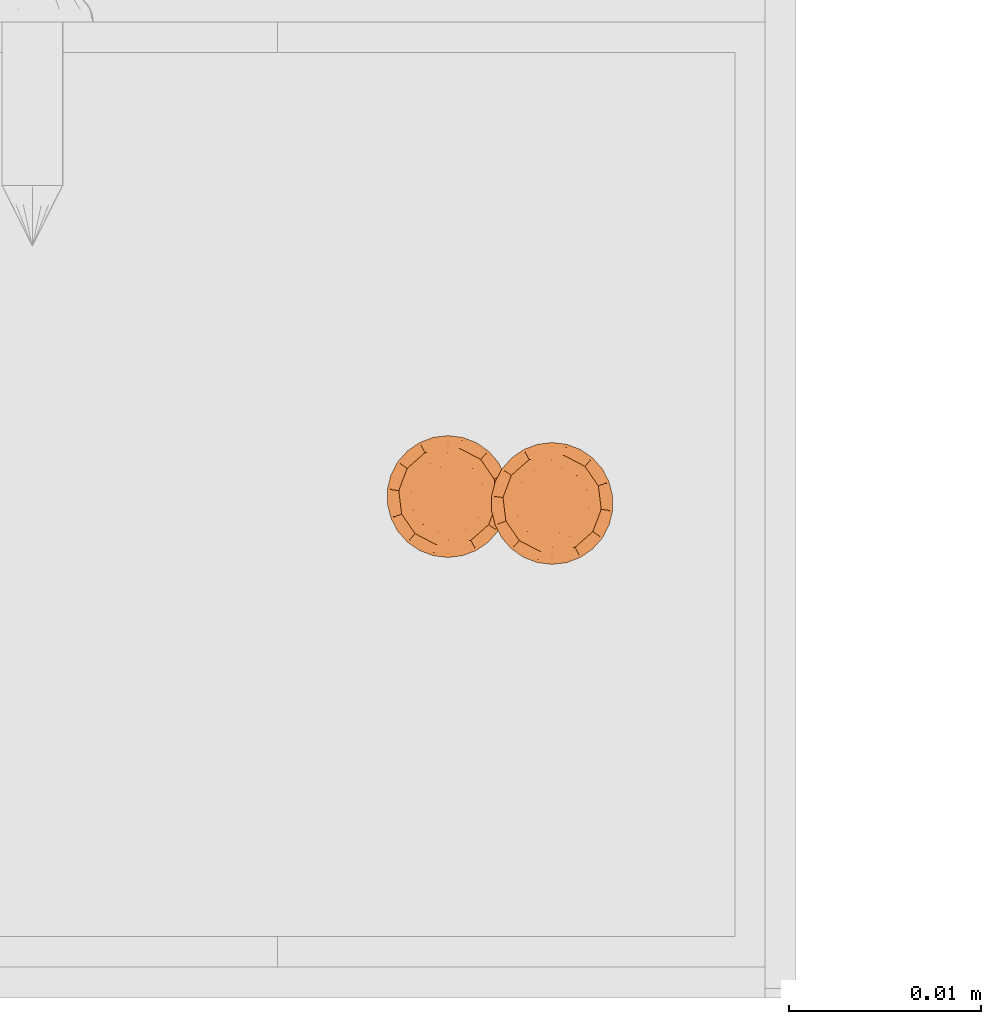
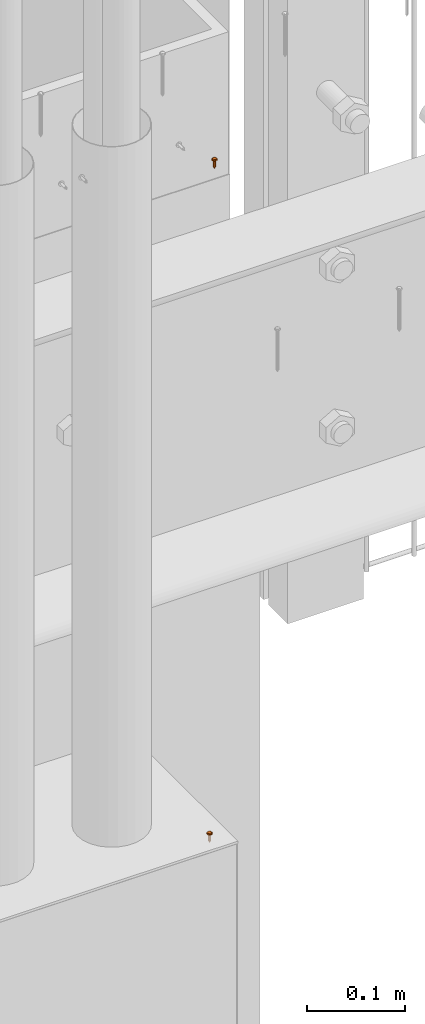
# One storey, part 43 of 44: 2 proxies.
"""IFC4 building model written with IfcOpenShell, lengths in feet."""

from ifc_helpers import new_model, entity, si_unit, converted_unit, derived_unit, direction, frame, origin, place, context, subcontext, project, spatial, source, transform, mapped, material, type_object, type_shapes, element, save


model = new_model("IFC4")

# Units and contexts
model_context = context("Model", 3, precision=0.0001, world=origin(), true_north=direction((6.12303176911189e-17, 1.0)))
body_context = subcontext(model_context, "Body", "Model", "MODEL_VIEW")
ifc_project = project(units=[converted_unit("LENGTHUNIT", "FOOT", entity("IfcRatioMeasure", 0.3048), si_unit("LENGTHUNIT", "METRE"), dimensions=[1, 0, 0, 0, 0, 0, 0]), converted_unit("AREAUNIT", "SQUARE FOOT", entity("IfcRatioMeasure", 0.09290304), si_unit("AREAUNIT", "SQUARE_METRE"), dimensions=[2, 0, 0, 0, 0, 0, 0]), converted_unit("VOLUMEUNIT", "CUBIC FOOT", entity("IfcRatioMeasure", 0.028316846592), si_unit("VOLUMEUNIT", "CUBIC_METRE"), dimensions=[3, 0, 0, 0, 0, 0, 0]), converted_unit("PLANEANGLEUNIT", "DEGREE", entity("IfcRatioMeasure", 0.0174532925199433), si_unit("PLANEANGLEUNIT", "RADIAN"), dimensions=[0, 0, 0, 0, 0, 0, 0]), si_unit("MASSUNIT", "GRAM", prefix="KILO"), derived_unit("MASSDENSITYUNIT", [(si_unit("MASSUNIT", "GRAM", prefix="KILO"), 1), (si_unit("LENGTHUNIT", "METRE"), -3)]), derived_unit("MOMENTOFINERTIAUNIT", [(si_unit("LENGTHUNIT", "METRE"), 4)]), si_unit("TIMEUNIT", "SECOND"), si_unit("FREQUENCYUNIT", "HERTZ"), si_unit("THERMODYNAMICTEMPERATUREUNIT", "DEGREE_CELSIUS"), derived_unit("THERMALTRANSMITTANCEUNIT", [(si_unit("MASSUNIT", "GRAM", prefix="KILO"), 1), (si_unit("THERMODYNAMICTEMPERATUREUNIT", "KELVIN"), -1), (si_unit("TIMEUNIT", "SECOND"), -3)]), derived_unit("VOLUMETRICFLOWRATEUNIT", [(si_unit("LENGTHUNIT", "METRE"), 3), (si_unit("TIMEUNIT", "SECOND"), -1)]), si_unit("ELECTRICCURRENTUNIT", "AMPERE"), si_unit("ELECTRICVOLTAGEUNIT", "VOLT"), si_unit("POWERUNIT", "WATT"), si_unit("FORCEUNIT", "NEWTON"), si_unit("ILLUMINANCEUNIT", "LUX"), si_unit("LUMINOUSFLUXUNIT", "LUMEN"), si_unit("LUMINOUSINTENSITYUNIT", "CANDELA"), derived_unit("USERDEFINED", [(si_unit("MASSUNIT", "GRAM", prefix="KILO"), -1), (si_unit("LENGTHUNIT", "METRE"), -2), (si_unit("TIMEUNIT", "SECOND"), 3), (si_unit("LUMINOUSFLUXUNIT", "LUMEN"), 1)]), derived_unit("LINEARVELOCITYUNIT", [(si_unit("LENGTHUNIT", "METRE"), 1), (si_unit("TIMEUNIT", "SECOND"), -1)]), si_unit("PRESSUREUNIT", "PASCAL"), derived_unit("USERDEFINED", [(si_unit("LENGTHUNIT", "METRE"), -2), (si_unit("MASSUNIT", "GRAM", prefix="KILO"), 1), (si_unit("TIMEUNIT", "SECOND"), -2)]), derived_unit("LINEARFORCEUNIT", [(si_unit("MASSUNIT", "GRAM", prefix="KILO"), 1), (si_unit("LENGTHUNIT", "METRE"), 1), (si_unit("TIMEUNIT", "SECOND"), -2), (si_unit("LENGTHUNIT", "METRE"), -1)]), derived_unit("PLANARFORCEUNIT", [(si_unit("MASSUNIT", "GRAM", prefix="KILO"), 1), (si_unit("LENGTHUNIT", "METRE"), 1), (si_unit("TIMEUNIT", "SECOND"), -2), (si_unit("LENGTHUNIT", "METRE"), -2)])], contexts=[model_context])

# Site, building, storey
site_placement = place(None, origin())
site = spatial("IfcSite", under=ifc_project, at=site_placement, CompositionType="ELEMENT")
building_placement = place(site_placement, origin())
building = spatial("IfcBuilding", under=site, at=building_placement, CompositionType="ELEMENT")
storey_placement = place(building_placement, origin())
storey = spatial("IfcBuildingStorey", under=building, at=storey_placement, CompositionType="ELEMENT", Elevation=0.0)

# Proxies
ifc_material_1 = material(Category="Materials")
building_element_proxy_type_1 = type_object("IfcBuildingElementProxyType", PredefinedType="NOTDEFINED", material=ifc_material_1)
cartesian_point_1 = entity("IfcCartesianPoint", [0.0, -0.00520833333344342, -0.0278812538651513])
vertex_point_1 = entity("IfcVertexPoint", cartesian_point_1)
cartesian_point_2 = entity("IfcCartesianPoint", [0.0, 0.00520833333334731, -0.0278812538651514])
vertex_point_2 = entity("IfcVertexPoint", cartesian_point_2)
cartesian_point_3 = entity("IfcCartesianPoint", [0.0, 0.0, -0.0278812538651514])
ifc_direction_1 = entity("IfcDirection", [0.0, 0.0, 1.0])
ifc_direction_2 = entity("IfcDirection", [0.0, 1.0, 0.0])
edge_curve_1 = entity("IfcEdgeCurve", vertex_point_1, vertex_point_2, entity("IfcTrimmedCurve", entity("IfcCircle", entity("IfcAxis2Placement3D", cartesian_point_3, ifc_direction_1, ifc_direction_2), 0.00520833333339537), [cartesian_point_1], [cartesian_point_2], True, "CARTESIAN"), True)
vertex_point_3 = entity("IfcVertexPoint", cartesian_point_3)
ifc_direction_3 = entity("IfcDirection", [0.0, -1.0, 0.0])
edge_curve_2 = entity("IfcEdgeCurve", vertex_point_2, vertex_point_3, entity("IfcTrimmedCurve", entity("IfcLine", cartesian_point_2, entity("IfcVector", ifc_direction_3, 1.0)), [cartesian_point_2], [cartesian_point_3], True, "CARTESIAN"), True)
edge_curve_3 = entity("IfcEdgeCurve", vertex_point_3, vertex_point_1, entity("IfcTrimmedCurve", entity("IfcLine", cartesian_point_3, entity("IfcVector", ifc_direction_3, 1.0)), [cartesian_point_3], [cartesian_point_1], True, "CARTESIAN"), True)
edge_curve_4 = entity("IfcEdgeCurve", vertex_point_2, vertex_point_1, entity("IfcTrimmedCurve", entity("IfcCircle", entity("IfcAxis2Placement3D", cartesian_point_3, ifc_direction_1, ifc_direction_2), 0.00520833333339537), [cartesian_point_2], [cartesian_point_1], True, "CARTESIAN"), True)
cartesian_point_4 = entity("IfcCartesianPoint", [0.0, 0.0, -0.0382979205315861])
vertex_point_4 = entity("IfcVertexPoint", cartesian_point_4)
edge_curve_5 = entity("IfcEdgeCurve", vertex_point_4, vertex_point_2, entity("IfcTrimmedCurve", entity("IfcLine", cartesian_point_4, entity("IfcVector", entity("IfcDirection", [0.0, 0.447213595512766, 0.894427190993512]), 1.0)), [cartesian_point_4], [cartesian_point_2], True, "CARTESIAN"), True)
edge_curve_6 = entity("IfcEdgeCurve", vertex_point_1, vertex_point_4, entity("IfcTrimmedCurve", entity("IfcLine", cartesian_point_1, entity("IfcVector", entity("IfcDirection", [0.0, 0.447213595512751, -0.894427190993519]), 1.0)), [cartesian_point_1], [cartesian_point_4], True, "CARTESIAN"), True)
cartesian_point_5 = entity("IfcCartesianPoint", [-0.0052083333333639, 0.0, -0.0278812538651513])
cartesian_point_6 = entity("IfcCartesianPoint", [0.0, 0.0, -0.0327501051227764])
ifc_direction_4 = entity("IfcDirection", [0.0, 0.0, -1.0])
cartesian_point_7 = entity("IfcCartesianPoint", [0.0, 0.0104166666665518, 0.0])
vertex_point_5 = entity("IfcVertexPoint", cartesian_point_7)
cartesian_point_8 = entity("IfcCartesianPoint", [0.0, -0.0104166666669052, 0.0])
vertex_point_6 = entity("IfcVertexPoint", cartesian_point_8)
cartesian_point_9 = entity("IfcCartesianPoint", [0.0, 0.0, 0.0])
ifc_direction_5 = entity("IfcDirection", [0.0, 0.0, -1.0])
ifc_direction_6 = entity("IfcDirection", [0.0, -1.0, 0.0])
edge_curve_7 = entity("IfcEdgeCurve", vertex_point_5, vertex_point_6, entity("IfcTrimmedCurve", entity("IfcCircle", entity("IfcAxis2Placement3D", cartesian_point_9, ifc_direction_5, ifc_direction_6), 0.0104166666667285), [cartesian_point_7], [cartesian_point_8], True, "CARTESIAN"), True)
vertex_point_7 = entity("IfcVertexPoint", cartesian_point_9)
ifc_direction_7 = entity("IfcDirection", [0.0, 1.0, 0.0])
edge_curve_8 = entity("IfcEdgeCurve", vertex_point_6, vertex_point_7, entity("IfcTrimmedCurve", entity("IfcLine", cartesian_point_8, entity("IfcVector", ifc_direction_7, 1.0)), [cartesian_point_8], [cartesian_point_9], True, "CARTESIAN"), True)
edge_curve_9 = entity("IfcEdgeCurve", vertex_point_7, vertex_point_5, entity("IfcTrimmedCurve", entity("IfcLine", cartesian_point_9, entity("IfcVector", ifc_direction_7, 1.0)), [cartesian_point_9], [cartesian_point_7], True, "CARTESIAN"), True)
edge_curve_10 = entity("IfcEdgeCurve", vertex_point_6, vertex_point_5, entity("IfcTrimmedCurve", entity("IfcCircle", entity("IfcAxis2Placement3D", cartesian_point_9, ifc_direction_5, ifc_direction_6), 0.0104166666667285), [cartesian_point_8], [cartesian_point_7], True, "CARTESIAN"), True)
cartesian_point_10 = entity("IfcCartesianPoint", [0.0, 0.0, 0.00520833333310164])
vertex_point_8 = entity("IfcVertexPoint", cartesian_point_10)
cartesian_point_11 = entity("IfcCartesianPoint", [0.0, -0.00520833333357187, 0.00520833333310168])
vertex_point_9 = entity("IfcVertexPoint", cartesian_point_11)
edge_curve_11 = entity("IfcEdgeCurve", vertex_point_8, vertex_point_9, entity("IfcTrimmedCurve", entity("IfcLine", cartesian_point_10, entity("IfcVector", ifc_direction_6, 1.0)), [cartesian_point_10], [cartesian_point_11], True, "CARTESIAN"), True)
cartesian_point_12 = entity("IfcCartesianPoint", [0.0, 0.00520833333321853, 0.00520833333310159])
vertex_point_10 = entity("IfcVertexPoint", cartesian_point_12)
ifc_direction_8 = entity("IfcDirection", [0.0, 0.0, 1.0])
edge_curve_12 = entity("IfcEdgeCurve", vertex_point_9, vertex_point_10, entity("IfcTrimmedCurve", entity("IfcCircle", entity("IfcAxis2Placement3D", cartesian_point_10, ifc_direction_8, ifc_direction_6), 0.00520833333339523), [cartesian_point_11], [cartesian_point_12], True, "CARTESIAN"), True)
edge_curve_13 = entity("IfcEdgeCurve", vertex_point_10, vertex_point_8, entity("IfcTrimmedCurve", entity("IfcLine", cartesian_point_12, entity("IfcVector", ifc_direction_6, 1.0)), [cartesian_point_12], [cartesian_point_10], True, "CARTESIAN"), True)
edge_curve_14 = entity("IfcEdgeCurve", vertex_point_10, vertex_point_9, entity("IfcTrimmedCurve", entity("IfcCircle", entity("IfcAxis2Placement3D", cartesian_point_10, ifc_direction_8, ifc_direction_6), 0.00520833333339523), [cartesian_point_12], [cartesian_point_11], True, "CARTESIAN"), True)
ifc_direction_9 = entity("IfcDirection", [1.0, 0.0, 0.0])
edge_curve_15 = entity("IfcEdgeCurve", vertex_point_9, vertex_point_6, entity("IfcTrimmedCurve", entity("IfcCircle", entity("IfcAxis2Placement3D", entity("IfcCartesianPoint", [0.0, -0.00520833333357193, 0.0]), ifc_direction_9, ifc_direction_6), 0.00520833333333331), [cartesian_point_11], [cartesian_point_8], True, "CARTESIAN"), True)
edge_curve_16 = entity("IfcEdgeCurve", vertex_point_5, vertex_point_10, entity("IfcTrimmedCurve", entity("IfcCircle", entity("IfcAxis2Placement3D", entity("IfcCartesianPoint", [0.0, 0.0052083333332185, 0.0]), ifc_direction_9, ifc_direction_7), 0.00520833333333331), [cartesian_point_7], [cartesian_point_12], True, "CARTESIAN"), True)
cartesian_point_13 = entity("IfcCartesianPoint", [0.00520833333332085, 0.0, 0.0])
cartesian_point_14 = entity("IfcCartesianPoint", [0.0104166666666542, 0.0, 0.0])
cartesian_point_15 = entity("IfcCartesianPoint", [0.0052083333333208, 0.0, 0.00520833333310163])
cartesian_point_16 = entity("IfcCartesianPoint", [0.0, -0.00520833333348769, 0.0])
vertex_point_11 = entity("IfcVertexPoint", cartesian_point_16)
cartesian_point_17 = entity("IfcCartesianPoint", [0.0, 0.00520833333317898, 0.0])
vertex_point_12 = entity("IfcVertexPoint", cartesian_point_17)
cartesian_point_18 = entity("IfcCartesianPoint", [0.0, 0.0, 0.0])
ifc_direction_10 = entity("IfcDirection", [0.0, 0.0, 1.0])
ifc_direction_11 = entity("IfcDirection", [0.0, 1.0, 0.0])
edge_curve_17 = entity("IfcEdgeCurve", vertex_point_11, vertex_point_12, entity("IfcTrimmedCurve", entity("IfcCircle", entity("IfcAxis2Placement3D", cartesian_point_18, ifc_direction_10, ifc_direction_11), 0.00520833333333333), [cartesian_point_16], [cartesian_point_17], True, "CARTESIAN"), True)
edge_curve_18 = entity("IfcEdgeCurve", vertex_point_12, vertex_point_11, entity("IfcTrimmedCurve", entity("IfcCircle", entity("IfcAxis2Placement3D", cartesian_point_18, ifc_direction_10, ifc_direction_11), 0.00520833333333333), [cartesian_point_17], [cartesian_point_16], True, "CARTESIAN"), True)
cartesian_point_19 = entity("IfcCartesianPoint", [0.0, -0.00520833333348793, -0.0278812538652589])
vertex_point_13 = entity("IfcVertexPoint", cartesian_point_19)
cartesian_point_20 = entity("IfcCartesianPoint", [0.0, 0.00520833333317874, -0.027881253865259])
vertex_point_14 = entity("IfcVertexPoint", cartesian_point_20)
cartesian_point_21 = entity("IfcCartesianPoint", [0.0, 0.0, -0.027881253865259])
ifc_direction_12 = entity("IfcDirection", [0.0, 0.0, -1.0])
edge_curve_19 = entity("IfcEdgeCurve", vertex_point_13, vertex_point_14, entity("IfcTrimmedCurve", entity("IfcCircle", entity("IfcAxis2Placement3D", cartesian_point_21, ifc_direction_12, ifc_direction_11), 0.00520833333333333), [cartesian_point_19], [cartesian_point_20], True, "CARTESIAN"), True)
edge_curve_20 = entity("IfcEdgeCurve", vertex_point_14, vertex_point_13, entity("IfcTrimmedCurve", entity("IfcCircle", entity("IfcAxis2Placement3D", cartesian_point_21, ifc_direction_12, ifc_direction_11), 0.00520833333333333), [cartesian_point_20], [cartesian_point_19], True, "CARTESIAN"), True)
edge_curve_21 = entity("IfcEdgeCurve", vertex_point_11, vertex_point_13, entity("IfcTrimmedCurve", entity("IfcLine", cartesian_point_16, entity("IfcVector", ifc_direction_12, 1.0)), [cartesian_point_16], [cartesian_point_19], True, "CARTESIAN"), True)
edge_curve_22 = entity("IfcEdgeCurve", vertex_point_14, vertex_point_12, entity("IfcTrimmedCurve", entity("IfcLine", cartesian_point_17, entity("IfcVector", ifc_direction_10, 1.0)), [cartesian_point_20], [cartesian_point_17], True, "CARTESIAN"), True)
shared_shape_1 = source(origin(), body_context, "Body", "AdvancedBrep", [
    entity("IfcAdvancedBrep", entity("IfcClosedShell", [entity("IfcAdvancedFace", [entity("IfcFaceOuterBound", entity("IfcEdgeLoop", [entity("IfcOrientedEdge", None, None, edge_curve_1, True), entity("IfcOrientedEdge", None, None, edge_curve_2, True), entity("IfcOrientedEdge", None, None, edge_curve_3, True)]), True)], entity("IfcPlane", entity("IfcAxis2Placement3D", cartesian_point_3, ifc_direction_1, ifc_direction_2)), True), entity("IfcAdvancedFace", [entity("IfcFaceOuterBound", entity("IfcEdgeLoop", [entity("IfcOrientedEdge", None, None, edge_curve_4, True), entity("IfcOrientedEdge", None, None, edge_curve_3, False), entity("IfcOrientedEdge", None, None, edge_curve_2, False)]), True)], entity("IfcPlane", entity("IfcAxis2Placement3D", cartesian_point_3, ifc_direction_1, ifc_direction_2)), True), entity("IfcAdvancedFace", [entity("IfcFaceOuterBound", entity("IfcEdgeLoop", [entity("IfcOrientedEdge", None, None, edge_curve_5, True), entity("IfcOrientedEdge", None, None, edge_curve_1, False), entity("IfcOrientedEdge", None, None, edge_curve_6, True)]), True)], entity("IfcSurfaceOfRevolution", entity("IfcArbitraryOpenProfileDef", "CURVE", None, entity("IfcTrimmedCurve", entity("IfcLine", cartesian_point_4, entity("IfcVector", entity("IfcDirection", [0.447213595512749, 0.0, -0.894427190993521]), 1.0)), [cartesian_point_5], [cartesian_point_4], True, "CARTESIAN")), None, entity("IfcAxis1Placement", cartesian_point_6, ifc_direction_4)), True), entity("IfcAdvancedFace", [entity("IfcFaceOuterBound", entity("IfcEdgeLoop", [entity("IfcOrientedEdge", None, None, edge_curve_6, False), entity("IfcOrientedEdge", None, None, edge_curve_4, False), entity("IfcOrientedEdge", None, None, edge_curve_5, False)]), True)], entity("IfcSurfaceOfRevolution", entity("IfcArbitraryOpenProfileDef", "CURVE", None, entity("IfcTrimmedCurve", entity("IfcLine", cartesian_point_4, entity("IfcVector", entity("IfcDirection", [0.447213595512749, 0.0, -0.894427190993521]), 1.0)), [cartesian_point_5], [cartesian_point_4], True, "CARTESIAN")), None, entity("IfcAxis1Placement", cartesian_point_6, ifc_direction_4)), True)])),
    entity("IfcAdvancedBrep", entity("IfcClosedShell", [entity("IfcAdvancedFace", [entity("IfcFaceOuterBound", entity("IfcEdgeLoop", [entity("IfcOrientedEdge", None, None, edge_curve_7, True), entity("IfcOrientedEdge", None, None, edge_curve_8, True), entity("IfcOrientedEdge", None, None, edge_curve_9, True)]), True)], entity("IfcPlane", entity("IfcAxis2Placement3D", cartesian_point_9, ifc_direction_5, ifc_direction_6)), True), entity("IfcAdvancedFace", [entity("IfcFaceOuterBound", entity("IfcEdgeLoop", [entity("IfcOrientedEdge", None, None, edge_curve_10, True), entity("IfcOrientedEdge", None, None, edge_curve_9, False), entity("IfcOrientedEdge", None, None, edge_curve_8, False)]), True)], entity("IfcPlane", entity("IfcAxis2Placement3D", cartesian_point_9, ifc_direction_5, ifc_direction_6)), True), entity("IfcAdvancedFace", [entity("IfcFaceOuterBound", entity("IfcEdgeLoop", [entity("IfcOrientedEdge", None, None, edge_curve_11, True), entity("IfcOrientedEdge", None, None, edge_curve_12, True), entity("IfcOrientedEdge", None, None, edge_curve_13, True)]), True)], entity("IfcPlane", entity("IfcAxis2Placement3D", cartesian_point_10, ifc_direction_8, ifc_direction_6)), True), entity("IfcAdvancedFace", [entity("IfcFaceOuterBound", entity("IfcEdgeLoop", [entity("IfcOrientedEdge", None, None, edge_curve_13, False), entity("IfcOrientedEdge", None, None, edge_curve_14, True), entity("IfcOrientedEdge", None, None, edge_curve_11, False)]), True)], entity("IfcPlane", entity("IfcAxis2Placement3D", cartesian_point_10, ifc_direction_8, ifc_direction_6)), True), entity("IfcAdvancedFace", [entity("IfcFaceOuterBound", entity("IfcEdgeLoop", [entity("IfcOrientedEdge", None, None, edge_curve_12, False), entity("IfcOrientedEdge", None, None, edge_curve_15, True), entity("IfcOrientedEdge", None, None, edge_curve_7, False), entity("IfcOrientedEdge", None, None, edge_curve_16, True)]), True)], entity("IfcSurfaceOfRevolution", entity("IfcArbitraryOpenProfileDef", "CURVE", None, entity("IfcTrimmedCurve", entity("IfcCircle", entity("IfcAxis2Placement3D", cartesian_point_13, ifc_direction_6, ifc_direction_9), 0.00520833333333331), [cartesian_point_14], [cartesian_point_15], True, "CARTESIAN")), None, entity("IfcAxis1Placement", cartesian_point_10, ifc_direction_8)), True), entity("IfcAdvancedFace", [entity("IfcFaceOuterBound", entity("IfcEdgeLoop", [entity("IfcOrientedEdge", None, None, edge_curve_14, False), entity("IfcOrientedEdge", None, None, edge_curve_16, False), entity("IfcOrientedEdge", None, None, edge_curve_10, False), entity("IfcOrientedEdge", None, None, edge_curve_15, False)]), True)], entity("IfcSurfaceOfRevolution", entity("IfcArbitraryOpenProfileDef", "CURVE", None, entity("IfcTrimmedCurve", entity("IfcCircle", entity("IfcAxis2Placement3D", cartesian_point_13, ifc_direction_6, ifc_direction_9), 0.00520833333333331), [cartesian_point_14], [cartesian_point_15], True, "CARTESIAN")), None, entity("IfcAxis1Placement", cartesian_point_10, ifc_direction_8)), True)])),
    entity("IfcAdvancedBrep", entity("IfcClosedShell", [entity("IfcAdvancedFace", [entity("IfcFaceOuterBound", entity("IfcEdgeLoop", [entity("IfcOrientedEdge", None, None, edge_curve_17, True), entity("IfcOrientedEdge", None, None, edge_curve_18, True)]), True)], entity("IfcPlane", entity("IfcAxis2Placement3D", cartesian_point_17, ifc_direction_10, entity("IfcDirection", [-1.0, 0.0, 0.0]))), True), entity("IfcAdvancedFace", [entity("IfcFaceOuterBound", entity("IfcEdgeLoop", [entity("IfcOrientedEdge", None, None, edge_curve_19, True), entity("IfcOrientedEdge", None, None, edge_curve_20, True)]), True)], entity("IfcPlane", entity("IfcAxis2Placement3D", cartesian_point_20, ifc_direction_12, entity("IfcDirection", [1.0, 0.0, 0.0]))), True), entity("IfcAdvancedFace", [entity("IfcFaceOuterBound", entity("IfcEdgeLoop", [entity("IfcOrientedEdge", None, None, edge_curve_17, False), entity("IfcOrientedEdge", None, None, edge_curve_21, True), entity("IfcOrientedEdge", None, None, edge_curve_20, False), entity("IfcOrientedEdge", None, None, edge_curve_22, True)]), True)], entity("IfcCylindricalSurface", entity("IfcAxis2Placement3D", cartesian_point_21, ifc_direction_10, ifc_direction_11), 0.00520833333333333), True), entity("IfcAdvancedFace", [entity("IfcFaceOuterBound", entity("IfcEdgeLoop", [entity("IfcOrientedEdge", None, None, edge_curve_18, False), entity("IfcOrientedEdge", None, None, edge_curve_22, False), entity("IfcOrientedEdge", None, None, edge_curve_19, False), entity("IfcOrientedEdge", None, None, edge_curve_21, False)]), True)], entity("IfcCylindricalSurface", entity("IfcAxis2Placement3D", cartesian_point_21, ifc_direction_10, ifc_direction_11), 0.00520833333333333), True)])),
])
type_shapes(building_element_proxy_type_1, [shared_shape_1])
proxy_1_placement = place(storey_placement, frame((1491.79333706317, 4.04030874652126, 8.00842457193066)))
element("IfcBuildingElementProxy", 1, at=proxy_1_placement, inside=storey, type_object=building_element_proxy_type_1, material=ifc_material_1, PredefinedType="NOTDEFINED", context=body_context, shape_type="MappedRepresentation", body=[
    mapped(shared_shape_1, transform((0.0, 0.0, 0.0), scale=1.0)),
])
ifc_material_2 = material(Category="Materials")
building_element_proxy_type_2 = type_object("IfcBuildingElementProxyType", PredefinedType="NOTDEFINED", material=ifc_material_2)
cartesian_point_22 = entity("IfcCartesianPoint", [0.0, -0.00520833333344342, -0.0278812538649932])
vertex_point_15 = entity("IfcVertexPoint", cartesian_point_22)
cartesian_point_23 = entity("IfcCartesianPoint", [0.0, 0.00520833333334731, -0.0278812538649933])
vertex_point_16 = entity("IfcVertexPoint", cartesian_point_23)
cartesian_point_24 = entity("IfcCartesianPoint", [0.0, 0.0, -0.0278812538649933])
ifc_direction_13 = entity("IfcDirection", [0.0, 0.0, 1.0])
ifc_direction_14 = entity("IfcDirection", [0.0, 1.0, 0.0])
edge_curve_23 = entity("IfcEdgeCurve", vertex_point_15, vertex_point_16, entity("IfcTrimmedCurve", entity("IfcCircle", entity("IfcAxis2Placement3D", cartesian_point_24, ifc_direction_13, ifc_direction_14), 0.00520833333339537), [cartesian_point_22], [cartesian_point_23], True, "CARTESIAN"), True)
vertex_point_17 = entity("IfcVertexPoint", cartesian_point_24)
ifc_direction_15 = entity("IfcDirection", [0.0, -1.0, 0.0])
edge_curve_24 = entity("IfcEdgeCurve", vertex_point_16, vertex_point_17, entity("IfcTrimmedCurve", entity("IfcLine", cartesian_point_23, entity("IfcVector", ifc_direction_15, 1.0)), [cartesian_point_23], [cartesian_point_24], True, "CARTESIAN"), True)
edge_curve_25 = entity("IfcEdgeCurve", vertex_point_17, vertex_point_15, entity("IfcTrimmedCurve", entity("IfcLine", cartesian_point_24, entity("IfcVector", ifc_direction_15, 1.0)), [cartesian_point_24], [cartesian_point_22], True, "CARTESIAN"), True)
edge_curve_26 = entity("IfcEdgeCurve", vertex_point_16, vertex_point_15, entity("IfcTrimmedCurve", entity("IfcCircle", entity("IfcAxis2Placement3D", cartesian_point_24, ifc_direction_13, ifc_direction_14), 0.00520833333339537), [cartesian_point_23], [cartesian_point_22], True, "CARTESIAN"), True)
cartesian_point_25 = entity("IfcCartesianPoint", [0.0, 0.0, -0.038297920531428])
vertex_point_18 = entity("IfcVertexPoint", cartesian_point_25)
edge_curve_27 = entity("IfcEdgeCurve", vertex_point_18, vertex_point_16, entity("IfcTrimmedCurve", entity("IfcLine", cartesian_point_25, entity("IfcVector", entity("IfcDirection", [0.0, 0.447213595512766, 0.894427190993512]), 1.0)), [cartesian_point_25], [cartesian_point_23], True, "CARTESIAN"), True)
edge_curve_28 = entity("IfcEdgeCurve", vertex_point_15, vertex_point_18, entity("IfcTrimmedCurve", entity("IfcLine", cartesian_point_22, entity("IfcVector", entity("IfcDirection", [0.0, 0.447213595512751, -0.894427190993519]), 1.0)), [cartesian_point_22], [cartesian_point_25], True, "CARTESIAN"), True)
cartesian_point_26 = entity("IfcCartesianPoint", [-0.0052083333333639, 0.0, -0.0278812538649932])
cartesian_point_27 = entity("IfcCartesianPoint", [0.0, 0.0, -0.0327501051226183])
ifc_direction_16 = entity("IfcDirection", [0.0, 0.0, -1.0])
cartesian_point_28 = entity("IfcCartesianPoint", [0.0, 0.0104166666665518, 0.0])
vertex_point_19 = entity("IfcVertexPoint", cartesian_point_28)
cartesian_point_29 = entity("IfcCartesianPoint", [0.0, -0.0104166666669052, 0.0])
vertex_point_20 = entity("IfcVertexPoint", cartesian_point_29)
cartesian_point_30 = entity("IfcCartesianPoint", [0.0, 0.0, 0.0])
ifc_direction_17 = entity("IfcDirection", [0.0, 0.0, -1.0])
ifc_direction_18 = entity("IfcDirection", [0.0, -1.0, 0.0])
edge_curve_29 = entity("IfcEdgeCurve", vertex_point_19, vertex_point_20, entity("IfcTrimmedCurve", entity("IfcCircle", entity("IfcAxis2Placement3D", cartesian_point_30, ifc_direction_17, ifc_direction_18), 0.0104166666667285), [cartesian_point_28], [cartesian_point_29], True, "CARTESIAN"), True)
vertex_point_21 = entity("IfcVertexPoint", cartesian_point_30)
ifc_direction_19 = entity("IfcDirection", [0.0, 1.0, 0.0])
edge_curve_30 = entity("IfcEdgeCurve", vertex_point_20, vertex_point_21, entity("IfcTrimmedCurve", entity("IfcLine", cartesian_point_29, entity("IfcVector", ifc_direction_19, 1.0)), [cartesian_point_29], [cartesian_point_30], True, "CARTESIAN"), True)
edge_curve_31 = entity("IfcEdgeCurve", vertex_point_21, vertex_point_19, entity("IfcTrimmedCurve", entity("IfcLine", cartesian_point_30, entity("IfcVector", ifc_direction_19, 1.0)), [cartesian_point_30], [cartesian_point_28], True, "CARTESIAN"), True)
edge_curve_32 = entity("IfcEdgeCurve", vertex_point_20, vertex_point_19, entity("IfcTrimmedCurve", entity("IfcCircle", entity("IfcAxis2Placement3D", cartesian_point_30, ifc_direction_17, ifc_direction_18), 0.0104166666667285), [cartesian_point_29], [cartesian_point_28], True, "CARTESIAN"), True)
cartesian_point_31 = entity("IfcCartesianPoint", [0.0, 0.0, 0.00520833333310164])
vertex_point_22 = entity("IfcVertexPoint", cartesian_point_31)
cartesian_point_32 = entity("IfcCartesianPoint", [0.0, -0.00520833333357187, 0.00520833333310168])
vertex_point_23 = entity("IfcVertexPoint", cartesian_point_32)
edge_curve_33 = entity("IfcEdgeCurve", vertex_point_22, vertex_point_23, entity("IfcTrimmedCurve", entity("IfcLine", cartesian_point_31, entity("IfcVector", ifc_direction_18, 1.0)), [cartesian_point_31], [cartesian_point_32], True, "CARTESIAN"), True)
cartesian_point_33 = entity("IfcCartesianPoint", [0.0, 0.00520833333321853, 0.00520833333310159])
vertex_point_24 = entity("IfcVertexPoint", cartesian_point_33)
ifc_direction_20 = entity("IfcDirection", [0.0, 0.0, 1.0])
edge_curve_34 = entity("IfcEdgeCurve", vertex_point_23, vertex_point_24, entity("IfcTrimmedCurve", entity("IfcCircle", entity("IfcAxis2Placement3D", cartesian_point_31, ifc_direction_20, ifc_direction_18), 0.00520833333339523), [cartesian_point_32], [cartesian_point_33], True, "CARTESIAN"), True)
edge_curve_35 = entity("IfcEdgeCurve", vertex_point_24, vertex_point_22, entity("IfcTrimmedCurve", entity("IfcLine", cartesian_point_33, entity("IfcVector", ifc_direction_18, 1.0)), [cartesian_point_33], [cartesian_point_31], True, "CARTESIAN"), True)
edge_curve_36 = entity("IfcEdgeCurve", vertex_point_24, vertex_point_23, entity("IfcTrimmedCurve", entity("IfcCircle", entity("IfcAxis2Placement3D", cartesian_point_31, ifc_direction_20, ifc_direction_18), 0.00520833333339523), [cartesian_point_33], [cartesian_point_32], True, "CARTESIAN"), True)
ifc_direction_21 = entity("IfcDirection", [1.0, 0.0, 0.0])
edge_curve_37 = entity("IfcEdgeCurve", vertex_point_23, vertex_point_20, entity("IfcTrimmedCurve", entity("IfcCircle", entity("IfcAxis2Placement3D", entity("IfcCartesianPoint", [0.0, -0.00520833333357193, 0.0]), ifc_direction_21, ifc_direction_18), 0.00520833333333331), [cartesian_point_32], [cartesian_point_29], True, "CARTESIAN"), True)
edge_curve_38 = entity("IfcEdgeCurve", vertex_point_19, vertex_point_24, entity("IfcTrimmedCurve", entity("IfcCircle", entity("IfcAxis2Placement3D", entity("IfcCartesianPoint", [0.0, 0.0052083333332185, 0.0]), ifc_direction_21, ifc_direction_19), 0.00520833333333331), [cartesian_point_28], [cartesian_point_33], True, "CARTESIAN"), True)
cartesian_point_34 = entity("IfcCartesianPoint", [0.00520833333332085, 0.0, 0.0])
cartesian_point_35 = entity("IfcCartesianPoint", [0.0104166666666542, 0.0, 0.0])
cartesian_point_36 = entity("IfcCartesianPoint", [0.0052083333333208, 0.0, 0.00520833333310163])
cartesian_point_37 = entity("IfcCartesianPoint", [0.0, -0.00520833333348769, 0.0])
vertex_point_25 = entity("IfcVertexPoint", cartesian_point_37)
cartesian_point_38 = entity("IfcCartesianPoint", [0.0, 0.00520833333317898, 0.0])
vertex_point_26 = entity("IfcVertexPoint", cartesian_point_38)
cartesian_point_39 = entity("IfcCartesianPoint", [0.0, 0.0, 0.0])
ifc_direction_22 = entity("IfcDirection", [0.0, 0.0, 1.0])
ifc_direction_23 = entity("IfcDirection", [0.0, 1.0, 0.0])
edge_curve_39 = entity("IfcEdgeCurve", vertex_point_25, vertex_point_26, entity("IfcTrimmedCurve", entity("IfcCircle", entity("IfcAxis2Placement3D", cartesian_point_39, ifc_direction_22, ifc_direction_23), 0.00520833333333333), [cartesian_point_37], [cartesian_point_38], True, "CARTESIAN"), True)
edge_curve_40 = entity("IfcEdgeCurve", vertex_point_26, vertex_point_25, entity("IfcTrimmedCurve", entity("IfcCircle", entity("IfcAxis2Placement3D", cartesian_point_39, ifc_direction_22, ifc_direction_23), 0.00520833333333333), [cartesian_point_38], [cartesian_point_37], True, "CARTESIAN"), True)
cartesian_point_40 = entity("IfcCartesianPoint", [0.0, -0.00520833333348793, -0.0278812538651009])
vertex_point_27 = entity("IfcVertexPoint", cartesian_point_40)
cartesian_point_41 = entity("IfcCartesianPoint", [0.0, 0.00520833333317874, -0.0278812538651009])
vertex_point_28 = entity("IfcVertexPoint", cartesian_point_41)
cartesian_point_42 = entity("IfcCartesianPoint", [0.0, 0.0, -0.0278812538651009])
ifc_direction_24 = entity("IfcDirection", [0.0, 0.0, -1.0])
edge_curve_41 = entity("IfcEdgeCurve", vertex_point_27, vertex_point_28, entity("IfcTrimmedCurve", entity("IfcCircle", entity("IfcAxis2Placement3D", cartesian_point_42, ifc_direction_24, ifc_direction_23), 0.00520833333333333), [cartesian_point_40], [cartesian_point_41], True, "CARTESIAN"), True)
edge_curve_42 = entity("IfcEdgeCurve", vertex_point_28, vertex_point_27, entity("IfcTrimmedCurve", entity("IfcCircle", entity("IfcAxis2Placement3D", cartesian_point_42, ifc_direction_24, ifc_direction_23), 0.00520833333333333), [cartesian_point_41], [cartesian_point_40], True, "CARTESIAN"), True)
edge_curve_43 = entity("IfcEdgeCurve", vertex_point_25, vertex_point_27, entity("IfcTrimmedCurve", entity("IfcLine", cartesian_point_37, entity("IfcVector", ifc_direction_24, 1.0)), [cartesian_point_37], [cartesian_point_40], True, "CARTESIAN"), True)
edge_curve_44 = entity("IfcEdgeCurve", vertex_point_28, vertex_point_26, entity("IfcTrimmedCurve", entity("IfcLine", cartesian_point_38, entity("IfcVector", ifc_direction_22, 1.0)), [cartesian_point_41], [cartesian_point_38], True, "CARTESIAN"), True)
shared_shape_2 = source(origin(), body_context, "Body", "AdvancedBrep", [
    entity("IfcAdvancedBrep", entity("IfcClosedShell", [entity("IfcAdvancedFace", [entity("IfcFaceOuterBound", entity("IfcEdgeLoop", [entity("IfcOrientedEdge", None, None, edge_curve_23, True), entity("IfcOrientedEdge", None, None, edge_curve_24, True), entity("IfcOrientedEdge", None, None, edge_curve_25, True)]), True)], entity("IfcPlane", entity("IfcAxis2Placement3D", cartesian_point_24, ifc_direction_13, ifc_direction_14)), True), entity("IfcAdvancedFace", [entity("IfcFaceOuterBound", entity("IfcEdgeLoop", [entity("IfcOrientedEdge", None, None, edge_curve_26, True), entity("IfcOrientedEdge", None, None, edge_curve_25, False), entity("IfcOrientedEdge", None, None, edge_curve_24, False)]), True)], entity("IfcPlane", entity("IfcAxis2Placement3D", cartesian_point_24, ifc_direction_13, ifc_direction_14)), True), entity("IfcAdvancedFace", [entity("IfcFaceOuterBound", entity("IfcEdgeLoop", [entity("IfcOrientedEdge", None, None, edge_curve_27, True), entity("IfcOrientedEdge", None, None, edge_curve_23, False), entity("IfcOrientedEdge", None, None, edge_curve_28, True)]), True)], entity("IfcSurfaceOfRevolution", entity("IfcArbitraryOpenProfileDef", "CURVE", None, entity("IfcTrimmedCurve", entity("IfcLine", cartesian_point_25, entity("IfcVector", entity("IfcDirection", [0.447213595512749, 0.0, -0.894427190993521]), 1.0)), [cartesian_point_26], [cartesian_point_25], True, "CARTESIAN")), None, entity("IfcAxis1Placement", cartesian_point_27, ifc_direction_16)), True), entity("IfcAdvancedFace", [entity("IfcFaceOuterBound", entity("IfcEdgeLoop", [entity("IfcOrientedEdge", None, None, edge_curve_28, False), entity("IfcOrientedEdge", None, None, edge_curve_26, False), entity("IfcOrientedEdge", None, None, edge_curve_27, False)]), True)], entity("IfcSurfaceOfRevolution", entity("IfcArbitraryOpenProfileDef", "CURVE", None, entity("IfcTrimmedCurve", entity("IfcLine", cartesian_point_25, entity("IfcVector", entity("IfcDirection", [0.447213595512749, 0.0, -0.894427190993521]), 1.0)), [cartesian_point_26], [cartesian_point_25], True, "CARTESIAN")), None, entity("IfcAxis1Placement", cartesian_point_27, ifc_direction_16)), True)])),
    entity("IfcAdvancedBrep", entity("IfcClosedShell", [entity("IfcAdvancedFace", [entity("IfcFaceOuterBound", entity("IfcEdgeLoop", [entity("IfcOrientedEdge", None, None, edge_curve_29, True), entity("IfcOrientedEdge", None, None, edge_curve_30, True), entity("IfcOrientedEdge", None, None, edge_curve_31, True)]), True)], entity("IfcPlane", entity("IfcAxis2Placement3D", cartesian_point_30, ifc_direction_17, ifc_direction_18)), True), entity("IfcAdvancedFace", [entity("IfcFaceOuterBound", entity("IfcEdgeLoop", [entity("IfcOrientedEdge", None, None, edge_curve_32, True), entity("IfcOrientedEdge", None, None, edge_curve_31, False), entity("IfcOrientedEdge", None, None, edge_curve_30, False)]), True)], entity("IfcPlane", entity("IfcAxis2Placement3D", cartesian_point_30, ifc_direction_17, ifc_direction_18)), True), entity("IfcAdvancedFace", [entity("IfcFaceOuterBound", entity("IfcEdgeLoop", [entity("IfcOrientedEdge", None, None, edge_curve_33, True), entity("IfcOrientedEdge", None, None, edge_curve_34, True), entity("IfcOrientedEdge", None, None, edge_curve_35, True)]), True)], entity("IfcPlane", entity("IfcAxis2Placement3D", cartesian_point_31, ifc_direction_20, ifc_direction_18)), True), entity("IfcAdvancedFace", [entity("IfcFaceOuterBound", entity("IfcEdgeLoop", [entity("IfcOrientedEdge", None, None, edge_curve_35, False), entity("IfcOrientedEdge", None, None, edge_curve_36, True), entity("IfcOrientedEdge", None, None, edge_curve_33, False)]), True)], entity("IfcPlane", entity("IfcAxis2Placement3D", cartesian_point_31, ifc_direction_20, ifc_direction_18)), True), entity("IfcAdvancedFace", [entity("IfcFaceOuterBound", entity("IfcEdgeLoop", [entity("IfcOrientedEdge", None, None, edge_curve_34, False), entity("IfcOrientedEdge", None, None, edge_curve_37, True), entity("IfcOrientedEdge", None, None, edge_curve_29, False), entity("IfcOrientedEdge", None, None, edge_curve_38, True)]), True)], entity("IfcSurfaceOfRevolution", entity("IfcArbitraryOpenProfileDef", "CURVE", None, entity("IfcTrimmedCurve", entity("IfcCircle", entity("IfcAxis2Placement3D", cartesian_point_34, ifc_direction_18, ifc_direction_21), 0.00520833333333331), [cartesian_point_35], [cartesian_point_36], True, "CARTESIAN")), None, entity("IfcAxis1Placement", cartesian_point_31, ifc_direction_20)), True), entity("IfcAdvancedFace", [entity("IfcFaceOuterBound", entity("IfcEdgeLoop", [entity("IfcOrientedEdge", None, None, edge_curve_36, False), entity("IfcOrientedEdge", None, None, edge_curve_38, False), entity("IfcOrientedEdge", None, None, edge_curve_32, False), entity("IfcOrientedEdge", None, None, edge_curve_37, False)]), True)], entity("IfcSurfaceOfRevolution", entity("IfcArbitraryOpenProfileDef", "CURVE", None, entity("IfcTrimmedCurve", entity("IfcCircle", entity("IfcAxis2Placement3D", cartesian_point_34, ifc_direction_18, ifc_direction_21), 0.00520833333333331), [cartesian_point_35], [cartesian_point_36], True, "CARTESIAN")), None, entity("IfcAxis1Placement", cartesian_point_31, ifc_direction_20)), True)])),
    entity("IfcAdvancedBrep", entity("IfcClosedShell", [entity("IfcAdvancedFace", [entity("IfcFaceOuterBound", entity("IfcEdgeLoop", [entity("IfcOrientedEdge", None, None, edge_curve_39, True), entity("IfcOrientedEdge", None, None, edge_curve_40, True)]), True)], entity("IfcPlane", entity("IfcAxis2Placement3D", cartesian_point_38, ifc_direction_22, entity("IfcDirection", [-1.0, 0.0, 0.0]))), True), entity("IfcAdvancedFace", [entity("IfcFaceOuterBound", entity("IfcEdgeLoop", [entity("IfcOrientedEdge", None, None, edge_curve_41, True), entity("IfcOrientedEdge", None, None, edge_curve_42, True)]), True)], entity("IfcPlane", entity("IfcAxis2Placement3D", cartesian_point_41, ifc_direction_24, entity("IfcDirection", [1.0, 0.0, 0.0]))), True), entity("IfcAdvancedFace", [entity("IfcFaceOuterBound", entity("IfcEdgeLoop", [entity("IfcOrientedEdge", None, None, edge_curve_39, False), entity("IfcOrientedEdge", None, None, edge_curve_43, True), entity("IfcOrientedEdge", None, None, edge_curve_42, False), entity("IfcOrientedEdge", None, None, edge_curve_44, True)]), True)], entity("IfcCylindricalSurface", entity("IfcAxis2Placement3D", cartesian_point_42, ifc_direction_22, ifc_direction_23), 0.00520833333333333), True), entity("IfcAdvancedFace", [entity("IfcFaceOuterBound", entity("IfcEdgeLoop", [entity("IfcOrientedEdge", None, None, edge_curve_40, False), entity("IfcOrientedEdge", None, None, edge_curve_44, False), entity("IfcOrientedEdge", None, None, edge_curve_41, False), entity("IfcOrientedEdge", None, None, edge_curve_43, False)]), True)], entity("IfcCylindricalSurface", entity("IfcAxis2Placement3D", cartesian_point_42, ifc_direction_22, ifc_direction_23), 0.00520833333333333), True)])),
])
type_shapes(building_element_proxy_type_2, [shared_shape_2])
proxy_2_placement = place(storey_placement, frame((1491.81114828999, 4.03912334427317, 10.7506104902959)))
element("IfcBuildingElementProxy", 2, at=proxy_2_placement, inside=storey, type_object=building_element_proxy_type_2, material=ifc_material_2, PredefinedType="NOTDEFINED", context=body_context, shape_type="MappedRepresentation", body=[
    mapped(shared_shape_2, transform((0.0, 0.0, 0.0), scale=1.0)),
])

save(model, "model.ifc")
